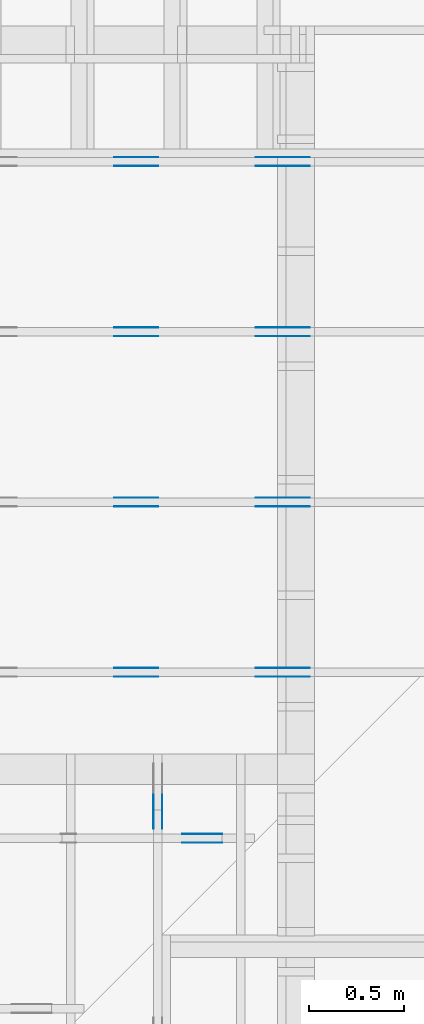
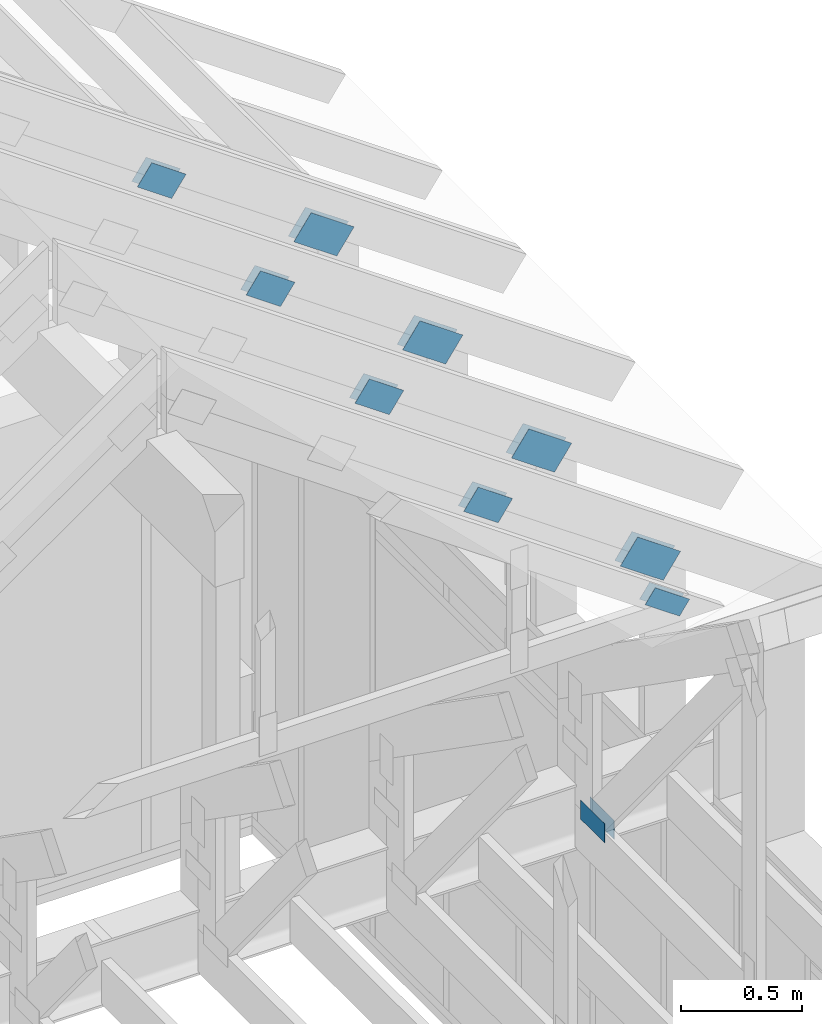
# One storey, part 65 of 70: 20 plates, 6 elements without a shape of their own.
"""IFC2X3 building model written with IfcOpenShell, lengths in millimetres."""

import ifcopenshell
import ifcopenshell.guid

model = None  # the IFC model being written
_history = None  # IfcOwnerHistory: only IFC2X3 demands one
_inside = {}  # id of a spatial element -> (the spatial element, [elements in it])
_under = {}  # id of a project, library or spatial element -> (it, [spatial elements below it])
_declared = {}  # id of a project -> (the project, [libraries it declares])
_typed = {}  # id of a type object -> (the type object, [elements of that type])
_made_of = {}  # id of a material, layer set ... -> (it, [elements and type objects made of it])


def new_model(schema):
    """Start an empty IFC model of exactly this schema.

    Asked for "IFC4X3", IfcOpenShell would pick the latest addendum, in which some entities
    have other attributes; the version numbers below select the first issue.
    IFC2X3 requires an IfcOwnerHistory on every rooted entity: one is made here for all.
    """
    global model, _history
    if schema == "IFC4X3":
        model = ifcopenshell.file(schema_version=(4, 3, 0, 0))
    else:
        model = ifcopenshell.file(schema=schema)
    _inside.clear()
    _under.clear()
    _declared.clear()
    _typed.clear()
    _made_of.clear()
    _history = None
    if model.schema == "IFC2X3":
        org = make("IfcOrganization", Name="unknown")
        user = make(
            "IfcPersonAndOrganization",
            ThePerson=make("IfcPerson", FamilyName="unknown"),
            TheOrganization=org,
        )
        app = make(
            "IfcApplication",
            ApplicationDeveloper=org,
            Version="unknown",
            ApplicationFullName="unknown",
            ApplicationIdentifier="unknown",
        )
        _history = make(
            "IfcOwnerHistory",
            OwningUser=user,
            OwningApplication=app,
            ChangeAction="ADDED",
            CreationDate=0,
        )
    return model


def make(cls, **values):
    """One entity of the class cls with the attributes given. An attribute that is None is left unset."""
    return model.create_entity(
        cls, **{name: value for name, value in values.items() if value is not None}
    )


def rooted(cls, **values):
    """An entity with a GlobalId (a new one), such as an element, a storey or a relation."""
    return make(cls, GlobalId=ifcopenshell.guid.new(), OwnerHistory=_history, **values)


def si_unit(unit_type, name, prefix=None):
    """IfcSIUnit, for example si_unit("LENGTHUNIT", "METRE", prefix="MILLI")."""
    return make("IfcSIUnit", UnitType=unit_type, Prefix=prefix, Name=name)


def assignment(units):
    """IfcUnitAssignment: the units of a project."""
    return None if units is None else make("IfcUnitAssignment", Units=units)


def point(xyz):
    """IfcCartesianPoint."""
    return None if xyz is None else make("IfcCartesianPoint", Coordinates=xyz)


def direction(xyz):
    """IfcDirection."""
    return None if xyz is None else make("IfcDirection", DirectionRatios=xyz)


def frame(location, z_axis=None, x_axis=None):
    """IfcAxis2Placement3D, a coordinate frame: its origin and axes. An axis left out is left unset."""
    return make(
        "IfcAxis2Placement3D",
        Location=point(location),
        Axis=direction(z_axis),
        RefDirection=direction(x_axis),
    )


def frame_2d(location, x_axis=None):
    """IfcAxis2Placement2D, a coordinate frame in the plane: its origin and x axis."""
    return make(
        "IfcAxis2Placement2D", Location=point(location), RefDirection=direction(x_axis)
    )


def origin():
    """The frame at (0, 0, 0) with its axes left unset."""
    return frame((0.0, 0.0, 0.0))


def origin_with_axes():
    """The frame at (0, 0, 0) with the z axis (0, 0, 1) and the x axis (1, 0, 0) written out."""
    return frame((0.0, 0.0, 0.0), z_axis=(0.0, 0.0, 1.0), x_axis=(1.0, 0.0, 0.0))


def origin_2d():
    """The frame at (0, 0) in the plane with its x axis left unset."""
    return frame_2d((0.0, 0.0))


def place(relative_to, where):
    """IfcLocalPlacement: puts the frame where relative to a parent placement (None: the world)."""
    return make(
        "IfcLocalPlacement", PlacementRelTo=relative_to, RelativePlacement=where
    )


def context(
    kind, dimensions, precision=None, world=None, true_north=None, identifier=None
):
    """IfcGeometricRepresentationContext, for example the 3D "Model" context."""
    return make(
        "IfcGeometricRepresentationContext",
        ContextIdentifier=identifier,
        ContextType=kind,
        CoordinateSpaceDimension=dimensions,
        Precision=precision,
        WorldCoordinateSystem=world,
        TrueNorth=true_north,
    )


def project(units=None, contexts=None):
    """IfcProject with its units and contexts."""
    return rooted(
        "IfcProject",
        Name="project",
        RepresentationContexts=contexts,
        UnitsInContext=assignment(units),
    )


def spatial(cls, under=None, at=None, **own):
    """A site, building, storey or space (cls), placed at a placement, below another one or the project."""
    s = rooted(cls, ObjectPlacement=at, **own)
    if under is not None:
        _under.setdefault(under.id(), (under, []))[1].append(s)
    return s


def faces_of(points, faces, orient=None, outer=None):
    """IfcFace entities. A face is a list of loops; a loop is a list of indices into points, from 0.

    orient and outer hold one flag for each loop. By default every Orientation is true, the
    first loop of a face is its IfcFaceOuterBound and the others are IfcFaceBound.
    """
    made = []
    for i, loops in enumerate(faces):
        bounds = []
        for j, loop in enumerate(loops):
            is_outer = j == 0 if outer is None else outer[i][j]
            bounds.append(
                make(
                    "IfcFaceOuterBound" if is_outer else "IfcFaceBound",
                    Bound=make("IfcPolyLoop", Polygon=[points[k] for k in loop]),
                    Orientation=True if orient is None else orient[i][j],
                )
            )
        made.append(make("IfcFace", Bounds=bounds))
    return made


def faceted_brep(points, faces, orient=None, outer=None, voids=None):
    """IfcFacetedBrep: a solid bounded by flat faces; with voids (closed shells), ...WithVoids."""
    shared = [point(p) for p in points]
    hull = make("IfcClosedShell", CfsFaces=faces_of(shared, faces, orient, outer))
    if voids is None:
        return make("IfcFacetedBrep", Outer=hull)
    return make(
        "IfcFacetedBrepWithVoids",
        Outer=hull,
        Voids=[
            make(cls, CfsFaces=faces_of(shared, fs, o, b)) for cls, fs, o, b in voids
        ],
    )


def shape(context_of_items, identifier, shape_type, items):
    """IfcShapeRepresentation: the items that make up one representation, for example the "Body"."""
    return make(
        "IfcShapeRepresentation",
        ContextOfItems=context_of_items,
        RepresentationIdentifier=identifier,
        RepresentationType=shape_type,
        Items=items,
    )


def made_of(thing, what):
    """Note that an element or type object is made of a material, layer set ...; save() writes the relation."""
    if what is not None:
        _made_of.setdefault(what.id(), (what, []))[1].append(thing)
    return thing


def element(
    cls,
    number,
    at=None,
    inside=None,
    cuts=None,
    type_object=None,
    material=None,
    context=None,
    identifier="Body",
    shape_type=None,
    held_by="IfcProductDefinitionShape",
    body=None,
    shapes=None,
    **own,
):
    """One element of the class cls, such as IfcWall. Its Tag is "e" and its number.

    at: its placement. inside: the storey or other place that contains it. cuts: it is an
    opening in that element (IfcRelVoidsElement). A single representation is given by context,
    identifier, shape_type and body (its items); several are given by shapes. held_by: the class
    of the entity that holds the representations. save() writes the other relations.
    """
    e = rooted(cls, Tag="e%d" % number, ObjectPlacement=at, **own)
    if body is not None:
        shapes = [shape(context, identifier, shape_type, body)]
    if shapes is not None:
        e.Representation = make(held_by, Representations=shapes)
    if inside is not None:
        _inside.setdefault(inside.id(), (inside, []))[1].append(e)
    if cuts is not None:
        rooted(
            "IfcRelVoidsElement", RelatingBuildingElement=cuts, RelatedOpeningElement=e
        )
    if type_object is not None:
        _typed.setdefault(type_object.id(), (type_object, []))[1].append(e)
    return made_of(e, material)


def aggregate(whole, parts):
    """IfcRelAggregates: a whole, such as a stair, and the parts it consists of."""
    return rooted("IfcRelAggregates", RelatingObject=whole, RelatedObjects=parts)


def save(model, path):
    """Write the relations noted so far, then the file.

    IfcRelAggregates (storeys below a building ...), IfcRelContainedInSpatialStructure (elements
    in a storey), IfcRelDefinesByType, IfcRelAssociatesMaterial and IfcRelDeclares: one each for
    every whole, place, type object, material and project.
    """
    for whole, parts in _under.values():
        aggregate(whole, parts)
    for where, things in _inside.values():
        rooted(
            "IfcRelContainedInSpatialStructure",
            RelatedElements=things,
            RelatingStructure=where,
        )
    for kind, things in _typed.values():
        rooted("IfcRelDefinesByType", RelatedObjects=things, RelatingType=kind)
    for what, things in _made_of.values():
        rooted("IfcRelAssociatesMaterial", RelatedObjects=things, RelatingMaterial=what)
    for by, libraries in _declared.values():
        rooted("IfcRelDeclares", RelatingContext=by, RelatedDefinitions=libraries)
    model.write(path)


model = new_model("IFC2X3")

# Units and contexts
model_context = context("Model", 3, precision=1e-05, world=origin())
plan_context = context("Plan", 2, precision=1e-05, world=origin_2d())
ifc_project = project(units=[si_unit("LENGTHUNIT", "METRE", prefix="MILLI"), si_unit("AREAUNIT", "SQUARE_METRE"), si_unit("VOLUMEUNIT", "CUBIC_METRE"), si_unit("SOLIDANGLEUNIT", "STERADIAN"), si_unit("PLANEANGLEUNIT", "RADIAN"), si_unit("MASSUNIT", "GRAM"), si_unit("TIMEUNIT", "SECOND"), si_unit("THERMODYNAMICTEMPERATUREUNIT", "DEGREE_CELSIUS"), si_unit("LUMINOUSINTENSITYUNIT", "LUMEN")], contexts=[model_context, plan_context])

# Site, building, storey
site_placement = place(None, origin_with_axes())
site = spatial("IfcSite", under=ifc_project, at=site_placement, CompositionType="ELEMENT")
building_placement = place(site_placement, origin_with_axes())
building = spatial("IfcBuilding", under=site, at=building_placement, Name="Layout 1", CompositionType="ELEMENT")
storey_placement = place(building_placement, origin_with_axes())
storey = spatial("IfcBuildingStorey", under=building, at=storey_placement, Name="Storey 1", CompositionType="ELEMENT", Elevation=0.0)

# Assembly, plates
assembly_1_placement = place(storey_placement, frame((11150.0, 8000.0, -9.081170196248781e-13), z_axis=(-1.0, 1.836909530733566e-16, 6.123031769111886e-17), x_axis=(-1.836909530733566e-16, -1.0, 0.0)))
assembly_1 = element("IfcElementAssembly", 1, at=assembly_1_placement, inside=storey, Name="T3", AssemblyPlace="FACTORY", PredefinedType="TRUSS")
plate_1_placement = place(assembly_1_placement, frame((44.999999998137355, 172.00000000000097, 0.0), z_axis=(0.0, 0.0, 1.0), x_axis=(1.0, 0.0, 0.0)))
plate_1 = element("IfcPlate", 2, at=plate_1_placement, context=model_context, shape_type="Brep", body=[
    faceted_brep([(200.0, 96.0, 1.3), (0.0, 96.0, 1.3), (0.0, 0.0, 1.3), (200.0, 0.0, 1.3), (0.0, 96.0, 0.0), (200.0, 96.0, 2.4492127076447545e-14), (200.0, 0.0, 2.4492127076447545e-14), (0.0, 0.0, 0.0), (200.0, -3.673819061467132e-14, 2.249491082733206e-30), (200.0, -3.6658591201672864e-14, 1.3), (1.4621692037765842e-32, 7.959941299845453e-17, 1.3), (0.0, 0.0, 0.0), (200.0, 96.0, 0.0), (200.0, 96.0, 1.3), (200.0, 0.0, 1.3), (200.0, 0.0, 0.0), (0.0, 96.0, 0.0), (-4.8738973459219465e-33, 96.0, 1.3), (200.0, 95.99999999999999, 1.3), (200.0, 95.99999999999999, -7.888609052210118e-31), (0.0, 0.0, 0.0), (7.959941299845453e-17, -9.747794691843893e-33, 1.3), (1.1835820409693277e-14, 96.0, 1.3), (1.1756220996694822e-14, 96.0, -7.19837146474626e-31)], [[[0, 1, 2, 3]], [[4, 5, 6, 7]], [[8, 9, 10, 11]], [[12, 13, 14, 15]], [[16, 17, 18, 19]], [[20, 21, 22, 23]]]),
])
plate_2_placement = place(assembly_1_placement, frame((44.999999998137355, 172.00000000000097, -46.3), z_axis=(0.0, 0.0, 1.0), x_axis=(1.0, 0.0, 0.0)))
plate_2 = element("IfcPlate", 3, at=plate_2_placement, context=model_context, shape_type="Brep", body=[
    faceted_brep([(200.0, 96.0, 1.2999999999999972), (0.0, 96.0, 1.2999999999999972), (0.0, 0.0, 1.2999999999999972), (200.0, 0.0, 1.2999999999999972), (0.0, 96.0, 0.0), (200.0, 96.0, 2.4492127076447545e-14), (200.0, 0.0, 2.4492127076447545e-14), (0.0, 0.0, 0.0), (200.0, -3.673819061467132e-14, 2.249491082733206e-30), (200.0, -3.6658591201672864e-14, 1.2999999999999972), (1.462169203776581e-32, 7.959941299845434e-17, 1.2999999999999972), (0.0, 0.0, 0.0), (200.0, 96.0, 0.0), (200.0, 96.0, 1.2999999999999972), (200.0, 0.0, 1.2999999999999972), (200.0, 0.0, 0.0), (0.0, 96.0, 0.0), (-4.873897345921936e-33, 96.0, 1.2999999999999972), (200.0, 95.99999999999999, 1.2999999999999972), (200.0, 95.99999999999999, -7.888609052210118e-31), (0.0, 0.0, 0.0), (7.959941299845434e-17, -9.747794691843873e-33, 1.2999999999999972), (1.1835820409693277e-14, 96.0, 1.2999999999999972), (1.1756220996694822e-14, 96.0, -7.19837146474626e-31)], [[[0, 1, 2, 3]], [[4, 5, 6, 7]], [[8, 9, 10, 11]], [[12, 13, 14, 15]], [[16, 17, 18, 19]], [[20, 21, 22, 23]]]),
])
aggregate(assembly_1, [plate_1, plate_2])

assembly_2_placement = place(storey_placement, frame((12000.0, 8605.0, 1.3776821480501744e-15), z_axis=(1.2246063538223773e-16, 1.0, 6.123031769111886e-17), x_axis=(-1.0, 1.2246063538223773e-16, 0.0)))
assembly_2 = element("IfcElementAssembly", 4, at=assembly_2_placement, inside=storey, Name="T10", AssemblyPlace="FACTORY", PredefinedType="TRUSS")
plate_3_placement = place(assembly_2_placement, frame((106.59842973764472, 748.6942088639203, 0.0), z_axis=(0.0, 0.0, 1.0), x_axis=(0.8191520442887201, 0.5735764363514341, 0.0)))
plate_3 = element("IfcPlate", 5, at=plate_3_placement, context=model_context, shape_type="Brep", body=[
    faceted_brep([(250.0, 144.0, 1.3), (0.0, 144.0, 1.3), (0.0, 0.0, 1.3), (250.0, 0.0, 1.3), (0.0, 144.0, 0.0), (250.0, 144.0, 3.061515884555943e-14), (250.0, 0.0, 3.061515884555943e-14), (0.0, 0.0, 0.0), (250.0, -4.592273826833915e-14, 2.8118638534165077e-30), (250.0, -4.5843138855340694e-14, 1.3), (1.4621692037765842e-32, 7.959941299845453e-17, 1.3), (0.0, 0.0, 0.0), (250.0, 144.0, 0.0), (250.0, 144.0, 1.3), (250.0, 0.0, 1.3), (250.0, 0.0, 0.0), (0.0, 144.0, 0.0), (-4.8738973459219465e-33, 144.0, 1.3), (250.0, 143.99999999999997, 1.3), (250.0, 143.99999999999997, -1.5777218104420236e-30), (0.0, 0.0, 0.0), (7.959941299845453e-17, -9.747794691843893e-33, 1.3), (1.7713930908040686e-14, 144.0, 1.3), (1.7634331495042233e-14, 144.0, -1.079755719711939e-30)], [[[0, 1, 2, 3]], [[4, 5, 6, 7]], [[8, 9, 10, 11]], [[12, 13, 14, 15]], [[16, 17, 18, 19]], [[20, 21, 22, 23]]]),
])
plate_4_placement = place(assembly_2_placement, frame((106.59842973764472, 748.6942088639203, -46.3), z_axis=(0.0, 0.0, 1.0), x_axis=(0.8191520442887201, 0.5735764363514341, 0.0)))
plate_4 = element("IfcPlate", 6, at=plate_4_placement, context=model_context, shape_type="Brep", body=[
    faceted_brep([(250.0, 144.0, 1.2999999999999972), (0.0, 144.0, 1.2999999999999972), (0.0, 0.0, 1.2999999999999972), (250.0, 0.0, 1.2999999999999972), (0.0, 144.0, 0.0), (250.0, 144.0, 3.061515884555943e-14), (250.0, 0.0, 3.061515884555943e-14), (0.0, 0.0, 0.0), (250.0, -4.592273826833915e-14, 2.8118638534165077e-30), (250.0, -4.5843138855340694e-14, 1.2999999999999972), (1.462169203776581e-32, 7.959941299845434e-17, 1.2999999999999972), (0.0, 0.0, 0.0), (250.0, 144.0, 0.0), (250.0, 144.0, 1.2999999999999972), (250.0, 0.0, 1.2999999999999972), (250.0, 0.0, 0.0), (0.0, 144.0, 0.0), (-4.873897345921936e-33, 144.0, 1.2999999999999972), (250.0, 143.99999999999997, 1.2999999999999972), (250.0, 143.99999999999997, -1.5777218104420236e-30), (0.0, 0.0, 0.0), (7.959941299845434e-17, -9.747794691843873e-33, 1.2999999999999972), (1.7713930908040686e-14, 144.0, 1.2999999999999972), (1.7634331495042233e-14, 144.0, -1.079755719711939e-30)], [[[0, 1, 2, 3]], [[4, 5, 6, 7]], [[8, 9, 10, 11]], [[12, 13, 14, 15]], [[16, 17, 18, 19]], [[20, 21, 22, 23]]]),
])
plate_5_placement = place(assembly_2_placement, frame((894.9492649036265, 1315.352701466824, 0.0), z_axis=(0.0, 0.0, 1.0), x_axis=(0.8191520442889921, 0.5735764363510459, 0.0)))
plate_5 = element("IfcPlate", 7, at=plate_5_placement, context=model_context, shape_type="Brep", body=[
    faceted_brep([(200.00000000000023, 119.99999999999966, 1.3), (0.0, 119.99999999999966, 1.3), (2.2737367544323206e-13, 0.0, 1.3), (200.00000000000023, 0.0, 1.3), (0.0, 119.99999999999966, 0.0), (200.00000000000023, 119.99999999999966, 2.4492127076447574e-14), (200.00000000000023, 0.0, 2.4492127076447574e-14), (2.2737367544323206e-13, 0.0, 2.78443247639729e-29), (200.00000000000023, -3.673819061467136e-14, 2.2494910827332086e-30), (200.00000000000023, -3.665859120167291e-14, 1.3), (2.2737367544323206e-13, 7.959941299841276e-17, 1.3), (2.2737367544323206e-13, -4.176648714595935e-29, 2.5573752767891235e-45), (200.00000000000023, 119.99999999999977, 0.0), (200.00000000000023, 119.99999999999977, 1.3), (200.00000000000023, 0.0, 1.3), (200.00000000000023, 0.0, 0.0), (0.0, 119.99999999999966, 0.0), (0.0, 119.99999999999966, 1.3), (200.00000000000023, 119.99999999999983, 1.3), (200.00000000000023, 119.99999999999983, 3.1554436208840472e-30), (2.2737367544323206e-13, 0.0, 0.0), (2.274532748562305e-13, 1.669984074232364e-31, 1.3), (-2.4304974807937842e-14, 119.99999999999966, 1.3), (-2.4384574220936276e-14, 119.99999999999966, 1.4930752263105939e-30)], [[[0, 1, 2, 3]], [[4, 5, 6, 7]], [[8, 9, 10, 11]], [[12, 13, 14, 15]], [[16, 17, 18, 19]], [[20, 21, 22, 23]]]),
])
plate_6_placement = place(assembly_2_placement, frame((894.9492649036265, 1315.352701466824, -46.300000000000004), z_axis=(0.0, 0.0, 1.0), x_axis=(0.8191520442889921, 0.5735764363510459, 0.0)))
plate_6 = element("IfcPlate", 8, at=plate_6_placement, context=model_context, shape_type="Brep", body=[
    faceted_brep([(200.00000000000023, 119.99999999999966, 1.2999999999999972), (0.0, 119.99999999999966, 1.2999999999999972), (2.2737367544323206e-13, 0.0, 1.2999999999999972), (200.00000000000023, 0.0, 1.2999999999999972), (0.0, 119.99999999999966, 0.0), (200.00000000000023, 119.99999999999966, 2.4492127076447574e-14), (200.00000000000023, 0.0, 2.4492127076447574e-14), (2.2737367544323206e-13, 0.0, 2.78443247639729e-29), (200.00000000000023, -3.673819061467136e-14, 2.2494910827332086e-30), (200.00000000000023, -3.665859120167291e-14, 1.2999999999999972), (2.2737367544323206e-13, 7.959941299841258e-17, 1.2999999999999972), (2.2737367544323206e-13, -4.176648714595935e-29, 2.5573752767891235e-45), (200.00000000000023, 119.99999999999977, 0.0), (200.00000000000023, 119.99999999999977, 1.2999999999999972), (200.00000000000023, 0.0, 1.2999999999999972), (200.00000000000023, 0.0, 0.0), (0.0, 119.99999999999966, 0.0), (0.0, 119.99999999999966, 1.2999999999999972), (200.00000000000023, 119.99999999999983, 1.2999999999999972), (200.00000000000023, 119.99999999999983, 3.1554436208840472e-30), (2.2737367544323206e-13, 0.0, 0.0), (2.274532748562305e-13, 1.669984074232364e-31, 1.2999999999999972), (-2.4304974807937842e-14, 119.99999999999966, 1.2999999999999972), (-2.4384574220936276e-14, 119.99999999999966, 1.4930752263105939e-30)], [[[0, 1, 2, 3]], [[4, 5, 6, 7]], [[8, 9, 10, 11]], [[12, 13, 14, 15]], [[16, 17, 18, 19]], [[20, 21, 22, 23]]]),
])
aggregate(assembly_2, [plate_3, plate_4, plate_5, plate_6])

assembly_3_placement = place(storey_placement, frame((12000.0, 9505.0, 1.3776821480501744e-15), z_axis=(1.2246063538223773e-16, 1.0, 6.123031769111886e-17), x_axis=(-1.0, 1.2246063538223773e-16, 0.0)))
assembly_3 = element("IfcElementAssembly", 9, at=assembly_3_placement, inside=storey, Name="T10", AssemblyPlace="FACTORY", PredefinedType="TRUSS")
plate_7_placement = place(assembly_3_placement, frame((106.59842973764472, 748.6942088639203, 0.0), z_axis=(0.0, 0.0, 1.0), x_axis=(0.8191520442887201, 0.5735764363514341, 0.0)))
plate_7 = element("IfcPlate", 10, at=plate_7_placement, context=model_context, shape_type="Brep", body=[
    faceted_brep([(250.0, 144.0, 1.3), (0.0, 144.0, 1.3), (0.0, 0.0, 1.3), (250.0, 0.0, 1.3), (0.0, 144.0, 0.0), (250.0, 144.0, 3.061515884555943e-14), (250.0, 0.0, 3.061515884555943e-14), (0.0, 0.0, 0.0), (250.0, -4.592273826833915e-14, 2.8118638534165077e-30), (250.0, -4.5843138855340694e-14, 1.3), (1.4621692037765842e-32, 7.959941299845453e-17, 1.3), (0.0, 0.0, 0.0), (250.0, 144.0, 0.0), (250.0, 144.0, 1.3), (250.0, 0.0, 1.3), (250.0, 0.0, 0.0), (0.0, 144.0, 0.0), (-4.8738973459219465e-33, 144.0, 1.3), (250.0, 143.99999999999997, 1.3), (250.0, 143.99999999999997, -1.5777218104420236e-30), (0.0, 0.0, 0.0), (7.959941299845453e-17, -9.747794691843893e-33, 1.3), (1.7713930908040686e-14, 144.0, 1.3), (1.7634331495042233e-14, 144.0, -1.079755719711939e-30)], [[[0, 1, 2, 3]], [[4, 5, 6, 7]], [[8, 9, 10, 11]], [[12, 13, 14, 15]], [[16, 17, 18, 19]], [[20, 21, 22, 23]]]),
])
plate_8_placement = place(assembly_3_placement, frame((106.59842973764472, 748.6942088639203, -46.3), z_axis=(0.0, 0.0, 1.0), x_axis=(0.8191520442887201, 0.5735764363514341, 0.0)))
plate_8 = element("IfcPlate", 11, at=plate_8_placement, context=model_context, shape_type="Brep", body=[
    faceted_brep([(250.0, 144.0, 1.2999999999999972), (0.0, 144.0, 1.2999999999999972), (0.0, 0.0, 1.2999999999999972), (250.0, 0.0, 1.2999999999999972), (0.0, 144.0, 0.0), (250.0, 144.0, 3.061515884555943e-14), (250.0, 0.0, 3.061515884555943e-14), (0.0, 0.0, 0.0), (250.0, -4.592273826833915e-14, 2.8118638534165077e-30), (250.0, -4.5843138855340694e-14, 1.2999999999999972), (1.462169203776581e-32, 7.959941299845434e-17, 1.2999999999999972), (0.0, 0.0, 0.0), (250.0, 144.0, 0.0), (250.0, 144.0, 1.2999999999999972), (250.0, 0.0, 1.2999999999999972), (250.0, 0.0, 0.0), (0.0, 144.0, 0.0), (-4.873897345921936e-33, 144.0, 1.2999999999999972), (250.0, 143.99999999999997, 1.2999999999999972), (250.0, 143.99999999999997, -1.5777218104420236e-30), (0.0, 0.0, 0.0), (7.959941299845434e-17, -9.747794691843873e-33, 1.2999999999999972), (1.7713930908040686e-14, 144.0, 1.2999999999999972), (1.7634331495042233e-14, 144.0, -1.079755719711939e-30)], [[[0, 1, 2, 3]], [[4, 5, 6, 7]], [[8, 9, 10, 11]], [[12, 13, 14, 15]], [[16, 17, 18, 19]], [[20, 21, 22, 23]]]),
])
plate_9_placement = place(assembly_3_placement, frame((894.9492649036265, 1315.352701466824, 0.0), z_axis=(0.0, 0.0, 1.0), x_axis=(0.8191520442889921, 0.5735764363510459, 0.0)))
plate_9 = element("IfcPlate", 12, at=plate_9_placement, context=model_context, shape_type="Brep", body=[
    faceted_brep([(200.00000000000023, 119.99999999999966, 1.3), (0.0, 119.99999999999966, 1.3), (2.2737367544323206e-13, 0.0, 1.3), (200.00000000000023, 0.0, 1.3), (0.0, 119.99999999999966, 0.0), (200.00000000000023, 119.99999999999966, 2.4492127076447574e-14), (200.00000000000023, 0.0, 2.4492127076447574e-14), (2.2737367544323206e-13, 0.0, 2.78443247639729e-29), (200.00000000000023, -3.673819061467136e-14, 2.2494910827332086e-30), (200.00000000000023, -3.665859120167291e-14, 1.3), (2.2737367544323206e-13, 7.959941299841276e-17, 1.3), (2.2737367544323206e-13, -4.176648714595935e-29, 2.5573752767891235e-45), (200.00000000000023, 119.99999999999977, 0.0), (200.00000000000023, 119.99999999999977, 1.3), (200.00000000000023, 0.0, 1.3), (200.00000000000023, 0.0, 0.0), (0.0, 119.99999999999966, 0.0), (0.0, 119.99999999999966, 1.3), (200.00000000000023, 119.99999999999983, 1.3), (200.00000000000023, 119.99999999999983, 3.1554436208840472e-30), (2.2737367544323206e-13, 0.0, 0.0), (2.274532748562305e-13, 1.669984074232364e-31, 1.3), (-2.4304974807937842e-14, 119.99999999999966, 1.3), (-2.4384574220936276e-14, 119.99999999999966, 1.4930752263105939e-30)], [[[0, 1, 2, 3]], [[4, 5, 6, 7]], [[8, 9, 10, 11]], [[12, 13, 14, 15]], [[16, 17, 18, 19]], [[20, 21, 22, 23]]]),
])
plate_10_placement = place(assembly_3_placement, frame((894.9492649036265, 1315.352701466824, -46.300000000000004), z_axis=(0.0, 0.0, 1.0), x_axis=(0.8191520442889921, 0.5735764363510459, 0.0)))
plate_10 = element("IfcPlate", 13, at=plate_10_placement, context=model_context, shape_type="Brep", body=[
    faceted_brep([(200.00000000000023, 119.99999999999966, 1.2999999999999972), (0.0, 119.99999999999966, 1.2999999999999972), (2.2737367544323206e-13, 0.0, 1.2999999999999972), (200.00000000000023, 0.0, 1.2999999999999972), (0.0, 119.99999999999966, 0.0), (200.00000000000023, 119.99999999999966, 2.4492127076447574e-14), (200.00000000000023, 0.0, 2.4492127076447574e-14), (2.2737367544323206e-13, 0.0, 2.78443247639729e-29), (200.00000000000023, -3.673819061467136e-14, 2.2494910827332086e-30), (200.00000000000023, -3.665859120167291e-14, 1.2999999999999972), (2.2737367544323206e-13, 7.959941299841258e-17, 1.2999999999999972), (2.2737367544323206e-13, -4.176648714595935e-29, 2.5573752767891235e-45), (200.00000000000023, 119.99999999999977, 0.0), (200.00000000000023, 119.99999999999977, 1.2999999999999972), (200.00000000000023, 0.0, 1.2999999999999972), (200.00000000000023, 0.0, 0.0), (0.0, 119.99999999999966, 0.0), (0.0, 119.99999999999966, 1.2999999999999972), (200.00000000000023, 119.99999999999983, 1.2999999999999972), (200.00000000000023, 119.99999999999983, 3.1554436208840472e-30), (2.2737367544323206e-13, 0.0, 0.0), (2.274532748562305e-13, 1.669984074232364e-31, 1.2999999999999972), (-2.4304974807937842e-14, 119.99999999999966, 1.2999999999999972), (-2.4384574220936276e-14, 119.99999999999966, 1.4930752263105939e-30)], [[[0, 1, 2, 3]], [[4, 5, 6, 7]], [[8, 9, 10, 11]], [[12, 13, 14, 15]], [[16, 17, 18, 19]], [[20, 21, 22, 23]]]),
])
aggregate(assembly_3, [plate_7, plate_8, plate_9, plate_10])

assembly_4_placement = place(storey_placement, frame((12000.0, 10405.0, 1.3776821480501744e-15), z_axis=(1.2246063538223773e-16, 1.0, 6.123031769111886e-17), x_axis=(-1.0, 1.2246063538223773e-16, 0.0)))
assembly_4 = element("IfcElementAssembly", 14, at=assembly_4_placement, inside=storey, Name="T10", AssemblyPlace="FACTORY", PredefinedType="TRUSS")
plate_11_placement = place(assembly_4_placement, frame((106.59842973764472, 748.6942088639203, 0.0), z_axis=(0.0, 0.0, 1.0), x_axis=(0.8191520442887201, 0.5735764363514341, 0.0)))
plate_11 = element("IfcPlate", 15, at=plate_11_placement, context=model_context, shape_type="Brep", body=[
    faceted_brep([(250.0, 144.0, 1.3), (0.0, 144.0, 1.3), (0.0, 0.0, 1.3), (250.0, 0.0, 1.3), (0.0, 144.0, 0.0), (250.0, 144.0, 3.061515884555943e-14), (250.0, 0.0, 3.061515884555943e-14), (0.0, 0.0, 0.0), (250.0, -4.592273826833915e-14, 2.8118638534165077e-30), (250.0, -4.5843138855340694e-14, 1.3), (1.4621692037765842e-32, 7.959941299845453e-17, 1.3), (0.0, 0.0, 0.0), (250.0, 144.0, 0.0), (250.0, 144.0, 1.3), (250.0, 0.0, 1.3), (250.0, 0.0, 0.0), (0.0, 144.0, 0.0), (-4.8738973459219465e-33, 144.0, 1.3), (250.0, 143.99999999999997, 1.3), (250.0, 143.99999999999997, -1.5777218104420236e-30), (0.0, 0.0, 0.0), (7.959941299845453e-17, -9.747794691843893e-33, 1.3), (1.7713930908040686e-14, 144.0, 1.3), (1.7634331495042233e-14, 144.0, -1.079755719711939e-30)], [[[0, 1, 2, 3]], [[4, 5, 6, 7]], [[8, 9, 10, 11]], [[12, 13, 14, 15]], [[16, 17, 18, 19]], [[20, 21, 22, 23]]]),
])
plate_12_placement = place(assembly_4_placement, frame((106.59842973764472, 748.6942088639203, -46.3), z_axis=(0.0, 0.0, 1.0), x_axis=(0.8191520442887201, 0.5735764363514341, 0.0)))
plate_12 = element("IfcPlate", 16, at=plate_12_placement, context=model_context, shape_type="Brep", body=[
    faceted_brep([(250.0, 144.0, 1.2999999999999972), (0.0, 144.0, 1.2999999999999972), (0.0, 0.0, 1.2999999999999972), (250.0, 0.0, 1.2999999999999972), (0.0, 144.0, 0.0), (250.0, 144.0, 3.061515884555943e-14), (250.0, 0.0, 3.061515884555943e-14), (0.0, 0.0, 0.0), (250.0, -4.592273826833915e-14, 2.8118638534165077e-30), (250.0, -4.5843138855340694e-14, 1.2999999999999972), (1.462169203776581e-32, 7.959941299845434e-17, 1.2999999999999972), (0.0, 0.0, 0.0), (250.0, 144.0, 0.0), (250.0, 144.0, 1.2999999999999972), (250.0, 0.0, 1.2999999999999972), (250.0, 0.0, 0.0), (0.0, 144.0, 0.0), (-4.873897345921936e-33, 144.0, 1.2999999999999972), (250.0, 143.99999999999997, 1.2999999999999972), (250.0, 143.99999999999997, -1.5777218104420236e-30), (0.0, 0.0, 0.0), (7.959941299845434e-17, -9.747794691843873e-33, 1.2999999999999972), (1.7713930908040686e-14, 144.0, 1.2999999999999972), (1.7634331495042233e-14, 144.0, -1.079755719711939e-30)], [[[0, 1, 2, 3]], [[4, 5, 6, 7]], [[8, 9, 10, 11]], [[12, 13, 14, 15]], [[16, 17, 18, 19]], [[20, 21, 22, 23]]]),
])
plate_13_placement = place(assembly_4_placement, frame((894.9492649036265, 1315.352701466824, 0.0), z_axis=(0.0, 0.0, 1.0), x_axis=(0.8191520442889921, 0.5735764363510459, 0.0)))
plate_13 = element("IfcPlate", 17, at=plate_13_placement, context=model_context, shape_type="Brep", body=[
    faceted_brep([(200.00000000000023, 119.99999999999966, 1.3), (0.0, 119.99999999999966, 1.3), (2.2737367544323206e-13, 0.0, 1.3), (200.00000000000023, 0.0, 1.3), (0.0, 119.99999999999966, 0.0), (200.00000000000023, 119.99999999999966, 2.4492127076447574e-14), (200.00000000000023, 0.0, 2.4492127076447574e-14), (2.2737367544323206e-13, 0.0, 2.78443247639729e-29), (200.00000000000023, -3.673819061467136e-14, 2.2494910827332086e-30), (200.00000000000023, -3.665859120167291e-14, 1.3), (2.2737367544323206e-13, 7.959941299841276e-17, 1.3), (2.2737367544323206e-13, -4.176648714595935e-29, 2.5573752767891235e-45), (200.00000000000023, 119.99999999999977, 0.0), (200.00000000000023, 119.99999999999977, 1.3), (200.00000000000023, 0.0, 1.3), (200.00000000000023, 0.0, 0.0), (0.0, 119.99999999999966, 0.0), (0.0, 119.99999999999966, 1.3), (200.00000000000023, 119.99999999999983, 1.3), (200.00000000000023, 119.99999999999983, 3.1554436208840472e-30), (2.2737367544323206e-13, 0.0, 0.0), (2.274532748562305e-13, 1.669984074232364e-31, 1.3), (-2.4304974807937842e-14, 119.99999999999966, 1.3), (-2.4384574220936276e-14, 119.99999999999966, 1.4930752263105939e-30)], [[[0, 1, 2, 3]], [[4, 5, 6, 7]], [[8, 9, 10, 11]], [[12, 13, 14, 15]], [[16, 17, 18, 19]], [[20, 21, 22, 23]]]),
])
plate_14_placement = place(assembly_4_placement, frame((894.9492649036265, 1315.352701466824, -46.300000000000004), z_axis=(0.0, 0.0, 1.0), x_axis=(0.8191520442889921, 0.5735764363510459, 0.0)))
plate_14 = element("IfcPlate", 18, at=plate_14_placement, context=model_context, shape_type="Brep", body=[
    faceted_brep([(200.00000000000023, 119.99999999999966, 1.2999999999999972), (0.0, 119.99999999999966, 1.2999999999999972), (2.2737367544323206e-13, 0.0, 1.2999999999999972), (200.00000000000023, 0.0, 1.2999999999999972), (0.0, 119.99999999999966, 0.0), (200.00000000000023, 119.99999999999966, 2.4492127076447574e-14), (200.00000000000023, 0.0, 2.4492127076447574e-14), (2.2737367544323206e-13, 0.0, 2.78443247639729e-29), (200.00000000000023, -3.673819061467136e-14, 2.2494910827332086e-30), (200.00000000000023, -3.665859120167291e-14, 1.2999999999999972), (2.2737367544323206e-13, 7.959941299841258e-17, 1.2999999999999972), (2.2737367544323206e-13, -4.176648714595935e-29, 2.5573752767891235e-45), (200.00000000000023, 119.99999999999977, 0.0), (200.00000000000023, 119.99999999999977, 1.2999999999999972), (200.00000000000023, 0.0, 1.2999999999999972), (200.00000000000023, 0.0, 0.0), (0.0, 119.99999999999966, 0.0), (0.0, 119.99999999999966, 1.2999999999999972), (200.00000000000023, 119.99999999999983, 1.2999999999999972), (200.00000000000023, 119.99999999999983, 3.1554436208840472e-30), (2.2737367544323206e-13, 0.0, 0.0), (2.274532748562305e-13, 1.669984074232364e-31, 1.2999999999999972), (-2.4304974807937842e-14, 119.99999999999966, 1.2999999999999972), (-2.4384574220936276e-14, 119.99999999999966, 1.4930752263105939e-30)], [[[0, 1, 2, 3]], [[4, 5, 6, 7]], [[8, 9, 10, 11]], [[12, 13, 14, 15]], [[16, 17, 18, 19]], [[20, 21, 22, 23]]]),
])
aggregate(assembly_4, [plate_11, plate_12, plate_13, plate_14])

assembly_5_placement = place(storey_placement, frame((12000.0, 11305.0, 1.3776821480501744e-15), z_axis=(1.2246063538223773e-16, 1.0, 6.123031769111886e-17), x_axis=(-1.0, 1.2246063538223773e-16, 0.0)))
assembly_5 = element("IfcElementAssembly", 19, at=assembly_5_placement, inside=storey, Name="T10", AssemblyPlace="FACTORY", PredefinedType="TRUSS")
plate_15_placement = place(assembly_5_placement, frame((106.59842973764472, 748.6942088639203, 0.0), z_axis=(0.0, 0.0, 1.0), x_axis=(0.8191520442887201, 0.5735764363514341, 0.0)))
plate_15 = element("IfcPlate", 20, at=plate_15_placement, context=model_context, shape_type="Brep", body=[
    faceted_brep([(250.0, 144.0, 1.3), (0.0, 144.0, 1.3), (0.0, 0.0, 1.3), (250.0, 0.0, 1.3), (0.0, 144.0, 0.0), (250.0, 144.0, 3.061515884555943e-14), (250.0, 0.0, 3.061515884555943e-14), (0.0, 0.0, 0.0), (250.0, -4.592273826833915e-14, 2.8118638534165077e-30), (250.0, -4.5843138855340694e-14, 1.3), (1.4621692037765842e-32, 7.959941299845453e-17, 1.3), (0.0, 0.0, 0.0), (250.0, 144.0, 0.0), (250.0, 144.0, 1.3), (250.0, 0.0, 1.3), (250.0, 0.0, 0.0), (0.0, 144.0, 0.0), (-4.8738973459219465e-33, 144.0, 1.3), (250.0, 143.99999999999997, 1.3), (250.0, 143.99999999999997, -1.5777218104420236e-30), (0.0, 0.0, 0.0), (7.959941299845453e-17, -9.747794691843893e-33, 1.3), (1.7713930908040686e-14, 144.0, 1.3), (1.7634331495042233e-14, 144.0, -1.079755719711939e-30)], [[[0, 1, 2, 3]], [[4, 5, 6, 7]], [[8, 9, 10, 11]], [[12, 13, 14, 15]], [[16, 17, 18, 19]], [[20, 21, 22, 23]]]),
])
plate_16_placement = place(assembly_5_placement, frame((106.59842973764472, 748.6942088639203, -46.3), z_axis=(0.0, 0.0, 1.0), x_axis=(0.8191520442887201, 0.5735764363514341, 0.0)))
plate_16 = element("IfcPlate", 21, at=plate_16_placement, context=model_context, shape_type="Brep", body=[
    faceted_brep([(250.0, 144.0, 1.2999999999999972), (0.0, 144.0, 1.2999999999999972), (0.0, 0.0, 1.2999999999999972), (250.0, 0.0, 1.2999999999999972), (0.0, 144.0, 0.0), (250.0, 144.0, 3.061515884555943e-14), (250.0, 0.0, 3.061515884555943e-14), (0.0, 0.0, 0.0), (250.0, -4.592273826833915e-14, 2.8118638534165077e-30), (250.0, -4.5843138855340694e-14, 1.2999999999999972), (1.462169203776581e-32, 7.959941299845434e-17, 1.2999999999999972), (0.0, 0.0, 0.0), (250.0, 144.0, 0.0), (250.0, 144.0, 1.2999999999999972), (250.0, 0.0, 1.2999999999999972), (250.0, 0.0, 0.0), (0.0, 144.0, 0.0), (-4.873897345921936e-33, 144.0, 1.2999999999999972), (250.0, 143.99999999999997, 1.2999999999999972), (250.0, 143.99999999999997, -1.5777218104420236e-30), (0.0, 0.0, 0.0), (7.959941299845434e-17, -9.747794691843873e-33, 1.2999999999999972), (1.7713930908040686e-14, 144.0, 1.2999999999999972), (1.7634331495042233e-14, 144.0, -1.079755719711939e-30)], [[[0, 1, 2, 3]], [[4, 5, 6, 7]], [[8, 9, 10, 11]], [[12, 13, 14, 15]], [[16, 17, 18, 19]], [[20, 21, 22, 23]]]),
])
plate_17_placement = place(assembly_5_placement, frame((894.9492649036265, 1315.352701466824, 0.0), z_axis=(0.0, 0.0, 1.0), x_axis=(0.8191520442889921, 0.5735764363510459, 0.0)))
plate_17 = element("IfcPlate", 22, at=plate_17_placement, context=model_context, shape_type="Brep", body=[
    faceted_brep([(200.00000000000023, 119.99999999999966, 1.3), (0.0, 119.99999999999966, 1.3), (2.2737367544323206e-13, 0.0, 1.3), (200.00000000000023, 0.0, 1.3), (0.0, 119.99999999999966, 0.0), (200.00000000000023, 119.99999999999966, 2.4492127076447574e-14), (200.00000000000023, 0.0, 2.4492127076447574e-14), (2.2737367544323206e-13, 0.0, 2.78443247639729e-29), (200.00000000000023, -3.673819061467136e-14, 2.2494910827332086e-30), (200.00000000000023, -3.665859120167291e-14, 1.3), (2.2737367544323206e-13, 7.959941299841276e-17, 1.3), (2.2737367544323206e-13, -4.176648714595935e-29, 2.5573752767891235e-45), (200.00000000000023, 119.99999999999977, 0.0), (200.00000000000023, 119.99999999999977, 1.3), (200.00000000000023, 0.0, 1.3), (200.00000000000023, 0.0, 0.0), (0.0, 119.99999999999966, 0.0), (0.0, 119.99999999999966, 1.3), (200.00000000000023, 119.99999999999983, 1.3), (200.00000000000023, 119.99999999999983, 3.1554436208840472e-30), (2.2737367544323206e-13, 0.0, 0.0), (2.274532748562305e-13, 1.669984074232364e-31, 1.3), (-2.4304974807937842e-14, 119.99999999999966, 1.3), (-2.4384574220936276e-14, 119.99999999999966, 1.4930752263105939e-30)], [[[0, 1, 2, 3]], [[4, 5, 6, 7]], [[8, 9, 10, 11]], [[12, 13, 14, 15]], [[16, 17, 18, 19]], [[20, 21, 22, 23]]]),
])
plate_18_placement = place(assembly_5_placement, frame((894.9492649036265, 1315.352701466824, -46.300000000000004), z_axis=(0.0, 0.0, 1.0), x_axis=(0.8191520442889921, 0.5735764363510459, 0.0)))
plate_18 = element("IfcPlate", 23, at=plate_18_placement, context=model_context, shape_type="Brep", body=[
    faceted_brep([(200.00000000000023, 119.99999999999966, 1.2999999999999972), (0.0, 119.99999999999966, 1.2999999999999972), (2.2737367544323206e-13, 0.0, 1.2999999999999972), (200.00000000000023, 0.0, 1.2999999999999972), (0.0, 119.99999999999966, 0.0), (200.00000000000023, 119.99999999999966, 2.4492127076447574e-14), (200.00000000000023, 0.0, 2.4492127076447574e-14), (2.2737367544323206e-13, 0.0, 2.78443247639729e-29), (200.00000000000023, -3.673819061467136e-14, 2.2494910827332086e-30), (200.00000000000023, -3.665859120167291e-14, 1.2999999999999972), (2.2737367544323206e-13, 7.959941299841258e-17, 1.2999999999999972), (2.2737367544323206e-13, -4.176648714595935e-29, 2.5573752767891235e-45), (200.00000000000023, 119.99999999999977, 0.0), (200.00000000000023, 119.99999999999977, 1.2999999999999972), (200.00000000000023, 0.0, 1.2999999999999972), (200.00000000000023, 0.0, 0.0), (0.0, 119.99999999999966, 0.0), (0.0, 119.99999999999966, 1.2999999999999972), (200.00000000000023, 119.99999999999983, 1.2999999999999972), (200.00000000000023, 119.99999999999983, 3.1554436208840472e-30), (2.2737367544323206e-13, 0.0, 0.0), (2.274532748562305e-13, 1.669984074232364e-31, 1.2999999999999972), (-2.4304974807937842e-14, 119.99999999999966, 1.2999999999999972), (-2.4384574220936276e-14, 119.99999999999966, 1.4930752263105939e-30)], [[[0, 1, 2, 3]], [[4, 5, 6, 7]], [[8, 9, 10, 11]], [[12, 13, 14, 15]], [[16, 17, 18, 19]], [[20, 21, 22, 23]]]),
])
aggregate(assembly_5, [plate_15, plate_16, plate_17, plate_18])

assembly_6_placement = place(storey_placement, frame((7294.999999999998, 7682.5, 1206.561223771864), z_axis=(0.0, -1.0, 6.123031769111886e-17), x_axis=(1.0, 0.0, 0.0)))
assembly_6 = element("IfcElementAssembly", 24, at=assembly_6_placement, inside=storey, Name="SB1", AssemblyPlace="FACTORY", PredefinedType="TRUSS")
plate_19_placement = place(assembly_6_placement, frame((4217.520846210046, 112.8014118347503, 0.0), z_axis=(0.0, 0.0, 1.0), x_axis=(-0.8191520442889919, 0.5735764363510459, 0.0)))
plate_19 = element("IfcPlate", 25, at=plate_19_placement, context=model_context, shape_type="Brep", body=[
    faceted_brep([(200.0, 84.00000000000045, 1.3), (4.547473508864641e-13, 84.00000000000045, 1.3), (0.0, 0.0, 1.3), (200.00000000000045, 0.0, 1.3), (4.547473508864641e-13, 84.00000000000045, 5.56886495279458e-29), (200.0, 84.00000000000045, 2.4492127076447545e-14), (200.00000000000045, 0.0, 2.4492127076447602e-14), (0.0, 0.0, 0.0), (200.00000000000045, -3.67381906146714e-14, 2.2494910827332114e-30), (200.00000000000045, -3.6658591201672947e-14, 1.3), (1.4621692037765842e-32, 7.959941299845453e-17, 1.3), (0.0, 0.0, 0.0), (200.00000000000045, 84.00000000000045, 2.8398992587956425e-29), (200.00000000000045, 84.00000000000045, 1.3), (200.00000000000045, 0.0, 1.3), (200.00000000000045, 0.0, 0.0), (4.547473508864641e-13, 84.00000000000045, 0.0), (4.547473508864641e-13, 84.00000000000045, 1.3), (200.0, 84.00000000000044, 1.3), (200.0, 84.00000000000044, -7.888609052210118e-31), (0.0, 0.0, 0.0), (7.959941299845453e-17, -4.339386797679936e-31, 1.3), (4.58008216313972e-13, 84.00000000000045, 1.3), (4.579286169009736e-13, 84.00000000000045, -1.9478992872837249e-31)], [[[0, 1, 2, 3]], [[4, 5, 6, 7]], [[8, 9, 10, 11]], [[12, 13, 14, 15]], [[16, 17, 18, 19]], [[20, 21, 22, 23]]]),
])
plate_20_placement = place(assembly_6_placement, frame((4217.520846210046, 112.8014118347503, -46.3), z_axis=(0.0, 0.0, 1.0), x_axis=(-0.8191520442889919, 0.5735764363510459, 0.0)))
plate_20 = element("IfcPlate", 26, at=plate_20_placement, context=model_context, shape_type="Brep", body=[
    faceted_brep([(200.0, 84.00000000000045, 1.2999999999999972), (4.547473508864641e-13, 84.00000000000045, 1.2999999999999972), (0.0, 0.0, 1.2999999999999972), (200.00000000000045, 0.0, 1.2999999999999972), (4.547473508864641e-13, 84.00000000000045, 5.56886495279458e-29), (200.0, 84.00000000000045, 2.4492127076447545e-14), (200.00000000000045, 0.0, 2.4492127076447602e-14), (0.0, 0.0, 0.0), (200.00000000000045, -3.67381906146714e-14, 2.2494910827332114e-30), (200.00000000000045, -3.6658591201672947e-14, 1.2999999999999972), (1.462169203776581e-32, 7.959941299845434e-17, 1.2999999999999972), (0.0, 0.0, 0.0), (200.00000000000045, 84.00000000000045, 2.8398992587956425e-29), (200.00000000000045, 84.00000000000045, 1.2999999999999972), (200.00000000000045, 0.0, 1.2999999999999972), (200.00000000000045, 0.0, 0.0), (4.547473508864641e-13, 84.00000000000045, 0.0), (4.547473508864641e-13, 84.00000000000045, 1.2999999999999972), (200.0, 84.00000000000044, 1.2999999999999972), (200.0, 84.00000000000044, -7.888609052210118e-31), (0.0, 0.0, 0.0), (7.959941299845434e-17, -4.339386797679926e-31, 1.2999999999999972), (4.58008216313972e-13, 84.00000000000045, 1.2999999999999972), (4.579286169009736e-13, 84.00000000000045, -1.9478992872837249e-31)], [[[0, 1, 2, 3]], [[4, 5, 6, 7]], [[8, 9, 10, 11]], [[12, 13, 14, 15]], [[16, 17, 18, 19]], [[20, 21, 22, 23]]]),
])
aggregate(assembly_6, [plate_19, plate_20])

save(model, "model.ifc")
